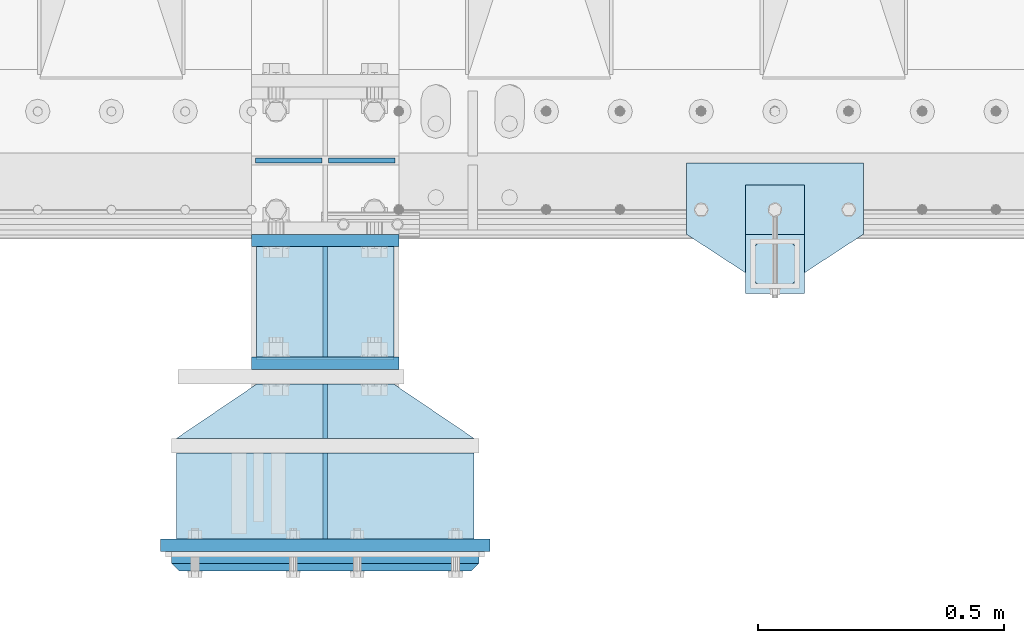
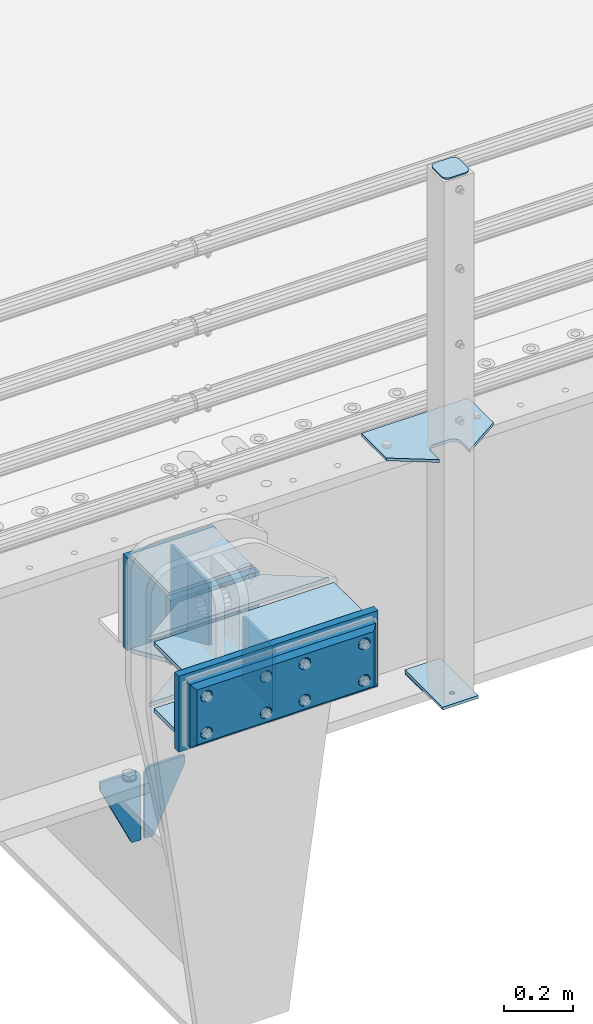
# One storey, part 223 of 270: 19 plates.
"""IFC2X3 building model written with IfcOpenShell, lengths in millimetres."""

from ifc_helpers import new_model, si_unit, frame, origin_with_axes, place, context, subcontext, project, spatial, faceted_brep, material, type_object, element, save


model = new_model("IFC2X3")

# Units and contexts
model_context = context("Model", 3, precision=1e-05, world=origin_with_axes())
body_context = subcontext(model_context, "Body", "Model", "MODEL_VIEW")
ifc_project = project(units=[si_unit("LENGTHUNIT", "METRE", prefix="MILLI"), si_unit("AREAUNIT", "SQUARE_METRE"), si_unit("VOLUMEUNIT", "CUBIC_METRE"), si_unit("MASSUNIT", "GRAM", prefix="KILO"), si_unit("TIMEUNIT", "SECOND"), si_unit("PLANEANGLEUNIT", "RADIAN"), si_unit("SOLIDANGLEUNIT", "STERADIAN"), si_unit("THERMODYNAMICTEMPERATUREUNIT", "DEGREE_CELSIUS"), si_unit("LUMINOUSINTENSITYUNIT", "LUMEN")], contexts=[model_context])

# Site, building, storey
site_placement = place(None, origin_with_axes())
site = spatial("IfcSite", under=ifc_project, at=site_placement, CompositionType="ELEMENT")
building_placement = place(site_placement, origin_with_axes())
building = spatial("IfcBuilding", under=site, at=building_placement, Name="Standard", CompositionType="ELEMENT")
storey_placement = place(building_placement, origin_with_axes())
storey = spatial("IfcBuildingStorey", under=building, at=storey_placement, Name="Undefined", CompositionType="ELEMENT", Elevation=0.0)

# Plates
ifc_material_1 = material(Name="STEEL/S355N")
plate_type_1 = type_object("IfcPlateType", PredefinedType="NOTDEFINED")
plate_1_placement = place(storey_placement, frame((13885.0000000054, -24162.5000000457, -350.00001823894), z_axis=(0.0, 0.0, 1.0), x_axis=(1.0, 0.0, 0.0)))
element("IfcPlate", 1, at=plate_1_placement, inside=storey, type_object=plate_type_1, material=ifc_material_1, context=body_context, shape_type="Brep", body=[
    faceted_brep([(0.0, -12.5, 0.0), (0.0, -12.5, 330.0), (0.0, 12.5, 330.0), (0.0, 12.5, 0.0), (300.0, -12.5, 330.0), (300.0, 12.5, 330.0), (300.0, -12.5, 0.0), (300.0, 12.5, 0.0)], [[[0, 1, 2, 3]], [[1, 4, 5, 2]], [[4, 6, 7, 5]], [[6, 0, 3, 7]], [[5, 7, 3, 2]], [[6, 4, 1, 0]]]),
])
plate_type_2 = type_object("IfcPlateType", PredefinedType="NOTDEFINED")
plate_2_placement = place(storey_placement, frame((14035.0000000058, -24175.0000000457, -346.00001823894), z_axis=(0.0, -1.0, 0.0), x_axis=(0.0, 0.0, 1.0)))
element("IfcPlate", 2, at=plate_2_placement, inside=storey, type_object=plate_type_2, material=ifc_material_1, context=body_context, shape_type="Brep", body=[
    faceted_brep([(0.0, -5.0, 0.0), (100.0, -5.0, 225.0), (100.0, 5.0, 225.0), (0.0, 5.0, 0.0), (322.0, -5.0, 225.0), (322.0, 5.0, 225.0), (322.0, -5.0, 0.0), (322.0, 5.0, 0.0)], [[[0, 1, 2, 3]], [[1, 4, 5, 2]], [[4, 6, 7, 5]], [[6, 0, 3, 7]], [[5, 7, 3, 2]], [[6, 4, 1, 0]]]),
])
ifc_material_2 = material(Name="STEEL/S355J2")
plate_type_3 = type_object("IfcPlateType", PredefinedType="NOTDEFINED")
plate_3_placement = place(storey_placement, frame((15130.0, -24005.0, 5.00000000004911), z_axis=(0.0, -1.0, 0.0), x_axis=(-1.0, 0.0, 0.0)))
element("IfcPlate", 3, at=plate_3_placement, inside=storey, type_object=plate_type_3, material=ifc_material_2, context=body_context, shape_type="Brep", body=[
    faceted_brep([(0.0, -5.0, 0.0), (2.31396552408114e-06, -5.0, 145.0), (2.31396552408114e-06, 5.0, 145.0), (0.0, 5.0, 0.0), (130.0, -5.0, 230.0), (130.0, 5.0, 230.0), (130.0, -5.0, 180.0), (130.0, 5.0, 180.0), (130.48036798992, -5.0, 175.122741949597), (130.48036798992, 5.0, 175.122741949597), (131.903011687216, -5.0, 170.432914190873), (131.903011687216, 5.0, 170.432914190873), (134.213259692435, -5.0, 166.11074417451), (134.213259692435, 5.0, 166.11074417451), (137.322330470335, -5.0, 162.322330470337), (137.322330470335, 5.0, 162.322330470337), (141.110744174512, -5.0, 159.213259692437), (141.110744174512, 5.0, 159.213259692437), (145.432914190871, -5.0, 156.903011687218), (145.432914190871, 5.0, 156.903011687218), (150.122741949595, -5.0, 155.48036798992), (150.122741949595, 5.0, 155.48036798992), (155.0, -5.0, 155.0), (155.0, 5.0, 155.0), (205.0, -5.0, 155.0), (205.0, 5.0, 155.0), (209.877258050405, -5.0, 155.48036798992), (209.877258050405, 5.0, 155.48036798992), (214.567085809129, -5.0, 156.903011687218), (214.567085809129, 5.0, 156.903011687218), (218.889255825488, -5.0, 159.213259692437), (218.889255825488, 5.0, 159.213259692437), (222.677669529665, -5.0, 162.322330470337), (222.677669529665, 5.0, 162.322330470337), (225.786740307565, -5.0, 166.11074417451), (225.786740307565, 5.0, 166.11074417451), (228.096988312784, -5.0, 170.432914190873), (228.096988312784, 5.0, 170.432914190873), (229.51963201008, -5.0, 175.122741949597), (229.51963201008, 5.0, 175.122741949597), (230.0, -5.0, 180.0), (230.0, 5.0, 180.0), (230.0, -5.0, 230.0), (230.0, 5.0, 230.0), (360.0, -5.0, 145.0), (360.0, 5.0, 145.0), (360.0, -5.0, -7.27595761418343e-12), (360.0, 5.0, -7.27595761418343e-12)], [[[0, 1, 2, 3]], [[1, 4, 5, 2]], [[4, 6, 7, 5]], [[6, 8, 9, 7]], [[8, 10, 11, 9]], [[10, 12, 13, 11]], [[12, 14, 15, 13]], [[14, 16, 17, 15]], [[16, 18, 19, 17]], [[18, 20, 21, 19]], [[20, 22, 23, 21]], [[22, 24, 25, 23]], [[24, 26, 27, 25]], [[26, 28, 29, 27]], [[28, 30, 31, 29]], [[30, 32, 33, 31]], [[32, 34, 35, 33]], [[34, 36, 37, 35]], [[36, 38, 39, 37]], [[38, 40, 41, 39]], [[40, 42, 43, 41]], [[42, 44, 45, 43]], [[44, 46, 47, 45]], [[46, 0, 3, 47]], [[5, 7, 9, 11, 13, 15, 17, 19, 21, 23, 25, 27, 29, 31, 33, 35, 37, 39, 41, 43, 45, 47, 3, 2]], [[46, 44, 42, 40, 38, 36, 34, 32, 30, 28, 26, 24, 22, 20, 18, 16, 14, 12, 10, 8, 6, 4, 1, 0]]]),
])
plate_type_4 = type_object("IfcPlateType", PredefinedType="NOTDEFINED")
plate_4_placement = place(storey_placement, frame((15009.9999999999, -24050.0000000002, -850.000000000002), z_axis=(0.0, -1.0, 0.0), x_axis=(-1.0, 0.0, 0.0)))
element("IfcPlate", 4, at=plate_4_placement, inside=storey, type_object=plate_type_4, material=ifc_material_2, context=body_context, shape_type="Brep", body=[
    faceted_brep([(53.6360389691836, -5.0, 176.363961030471), (53.6360389691836, 5.0, 176.363961030471), (59.9999999998618, 5.0, 178.999999999793), (59.9999999998618, -5.0, 178.999999999793), (66.3639610305399, 5.0, 176.363961030471), (66.3639610305399, -5.0, 176.363961030471), (68.9999999998618, 5.0, 169.999999999793), (68.9999999998618, -5.0, 169.999999999793), (66.3639610305399, 5.0, 163.636038969114), (66.3639610305399, -5.0, 163.636038969114), (59.9999999998618, 5.0, 160.999999999793), (59.9999999998618, -5.0, 160.999999999793), (53.6360389691836, 5.0, 163.636038969114), (53.6360389691836, -5.0, 163.636038969114), (50.9999999998618, 5.0, 169.999999999793), (50.9999999998618, -5.0, 169.999999999793), (120.0, -5.0, 0.0), (120.0, -5.0, 220.0), (0.0, -5.0, 220.0), (0.0, -5.0, 0.0), (0.0, 5.0, 0.0), (120.0, 5.0, 0.0), (120.0, 5.0, 220.0), (0.0, 5.0, 220.0)], [[[0, 1, 2, 3]], [[3, 2, 4, 5]], [[5, 4, 6, 7]], [[7, 6, 8, 9]], [[9, 8, 10, 11]], [[11, 10, 12, 13]], [[13, 12, 14, 15]], [[15, 14, 1, 0]], [[16, 17, 18, 19], [11, 13, 15, 0, 3, 5, 7, 9]], [[16, 19, 20, 21]], [[17, 16, 21, 22]], [[18, 17, 22, 23]], [[19, 18, 23, 20]], [[22, 21, 20, 23], [2, 1, 14, 12, 10, 8, 6, 4]]]),
])
plate_type_5 = type_object("IfcPlateType", PredefinedType="NOTDEFINED")
plate_5_placement = place(storey_placement, frame((14905.9999999999, -24166.0000000002, 1012.50000000001), z_axis=(0.0, -1.0, 0.0), x_axis=(1.0, 0.0, 0.0)))
element("IfcPlate", 5, at=plate_5_placement, inside=storey, type_object=plate_type_5, material=ifc_material_2, context=body_context, shape_type="Brep", body=[
    faceted_brep([(0.0, -2.5, 19.0), (0.0, -2.5, 69.0), (0.0, 2.5, 69.0), (0.0, 2.5, 19.0), (0.476369668544066, -2.5, 73.2278977451697), (0.476369668544066, 2.5, 73.2278977451697), (1.88159150985302, -2.5, 77.2437910432327), (1.88159150985302, 2.5, 77.2437910432327), (4.14520183310742, -2.5, 80.8463062353167), (4.14520183310742, 2.5, 80.8463062353167), (7.15369376468516, -2.5, 83.8547981668926), (7.15369376468516, 2.5, 83.8547981668926), (10.7562089567655, -2.5, 86.1184084901452), (10.7562089567655, 2.5, 86.1184084901452), (14.7721022548285, -2.5, 87.5236303314541), (14.7721022548285, 2.5, 87.5236303314541), (19.0, -2.5, 88.0), (19.0, 2.5, 88.0), (69.0, -2.5, 88.0), (69.0, 2.5, 88.0), (73.2278977451715, -2.5, 87.5236303314541), (73.2278977451715, 2.5, 87.5236303314541), (77.2437910432345, -2.5, 86.1184084901452), (77.2437910432345, 2.5, 86.1184084901452), (80.8463062353148, -2.5, 83.8547981668926), (80.8463062353148, 2.5, 83.8547981668926), (83.8547981668926, -2.5, 80.8463062353167), (83.8547981668926, 2.5, 80.8463062353167), (86.118408490147, -2.5, 77.2437910432345), (86.118408490147, 2.5, 77.2437910432345), (87.5236303314559, -2.5, 73.2278977451697), (87.5236303314559, 2.5, 73.2278977451697), (88.0, -2.5, 69.0), (88.0, 2.5, 69.0), (88.0, -2.5, 19.0), (88.0, 2.5, 19.0), (87.5236303314559, -2.5, 14.7721022548303), (87.5236303314559, 2.5, 14.7721022548303), (86.118408490147, -2.5, 10.7562089567673), (86.118408490147, 2.5, 10.7562089567673), (83.8547981668926, -2.5, 7.15369376468334), (83.8547981668926, 2.5, 7.15369376468334), (80.8463062353148, -2.5, 4.14520183310742), (80.8463062353148, 2.5, 4.14520183310742), (77.2437910432345, -2.5, 1.88159150985484), (77.2437910432345, 2.5, 1.88159150985484), (73.2278977451715, -2.5, 0.476369668545885), (73.2278977451715, 2.5, 0.476369668545885), (69.0, -2.5, 0.0), (69.0, 2.5, 0.0), (19.0, -2.5, 0.0), (19.0, 2.5, 0.0), (14.7721022548285, -2.5, 0.476369668545885), (14.7721022548285, 2.5, 0.476369668545885), (10.7562089567655, -2.5, 1.88159150985484), (10.7562089567655, 2.5, 1.88159150985484), (7.15369376468516, -2.5, 4.14520183310742), (7.15369376468516, 2.5, 4.14520183310742), (4.14520183310742, -2.5, 7.15369376468334), (4.14520183310742, 2.5, 7.15369376468334), (1.88159150985302, -2.5, 10.7562089567673), (1.88159150985302, 2.5, 10.7562089567673), (0.476369668544066, -2.5, 14.7721022548303), (0.476369668544066, 2.5, 14.7721022548303)], [[[0, 1, 2, 3]], [[1, 4, 5, 2]], [[4, 6, 7, 5]], [[6, 8, 9, 7]], [[8, 10, 11, 9]], [[10, 12, 13, 11]], [[12, 14, 15, 13]], [[14, 16, 17, 15]], [[16, 18, 19, 17]], [[18, 20, 21, 19]], [[20, 22, 23, 21]], [[22, 24, 25, 23]], [[24, 26, 27, 25]], [[26, 28, 29, 27]], [[28, 30, 31, 29]], [[30, 32, 33, 31]], [[32, 34, 35, 33]], [[34, 36, 37, 35]], [[36, 38, 39, 37]], [[38, 40, 41, 39]], [[40, 42, 43, 41]], [[42, 44, 45, 43]], [[44, 46, 47, 45]], [[46, 48, 49, 47]], [[48, 50, 51, 49]], [[50, 52, 53, 51]], [[52, 54, 55, 53]], [[54, 56, 57, 55]], [[56, 58, 59, 57]], [[58, 60, 61, 59]], [[60, 62, 63, 61]], [[62, 0, 3, 63]], [[5, 7, 9, 11, 13, 15, 17, 19, 21, 23, 25, 27, 29, 31, 33, 35, 37, 39, 41, 43, 45, 47, 49, 51, 53, 55, 57, 59, 61, 63, 3, 2]], [[62, 60, 58, 56, 54, 52, 50, 48, 46, 44, 42, 40, 38, 36, 34, 32, 30, 28, 26, 24, 22, 20, 18, 16, 14, 12, 10, 8, 6, 4, 1, 0]]]),
])
plate_type_6 = type_object("IfcPlateType", PredefinedType="NOTDEFINED")
plate_6_placement = place(storey_placement, frame((15009.9999999999, -24050.0000000002, -857.500000000002), z_axis=(0.0, -1.0, 0.0), x_axis=(-1.0, 0.0, 0.0)))
element("IfcPlate", 6, at=plate_6_placement, inside=storey, type_object=plate_type_6, material=ifc_material_2, context=body_context, shape_type="Brep", body=[
    faceted_brep([(0.0, -2.5, 0.0), (0.0, -2.5, 100.0), (0.0, 2.5, 100.0), (0.0, 2.5, 0.0), (120.0, -2.5, 100.0), (120.0, 2.5, 100.0), (120.0, -2.5, 0.0), (120.0, 2.5, 0.0)], [[[0, 1, 2, 3]], [[1, 4, 5, 2]], [[4, 6, 7, 5]], [[6, 0, 3, 7]], [[5, 7, 3, 2]], [[6, 4, 1, 0]]]),
])
plate_type_7 = type_object("IfcPlateType", PredefinedType="NOTDEFINED")
for number, where, z_axis, x_axis in (
    (7, (14028.5000000058, -24000.0000000457, -925.000018238938), (0.0, 0.0, -1.0), (-1.0, 0.0, 0.0)),
    (8, (14041.5000000058, -24000.0000000457, -925.000018238938), (0.0, 0.0, -1.0), (1.0, 0.0, 0.0)),
):
    element("IfcPlate", number, at=place(storey_placement, frame(where, z_axis=z_axis, x_axis=x_axis)), inside=storey, type_object=plate_type_7, material=ifc_material_1, context=body_context, shape_type="Brep", body=[
        faceted_brep([(0.0, -5.0, 27.0), (0.0, -5.0, 250.0), (0.0, 5.0, 250.0), (0.0, 5.0, 27.0), (30.0, -5.0, 250.0), (30.0, 5.0, 250.0), (135.0, -5.0, 30.0), (135.0, 5.0, 30.0), (135.0, -5.0, 0.0), (135.0, 5.0, 0.0), (27.0, -5.0, 0.0), (27.0, 5.0, 0.0), (22.3114992029932, -5.0, 0.410190668670339), (22.3114992029932, 5.0, 0.410190668670339), (17.7654561302061, -5.0, 1.62829923878053), (17.7654561302061, 5.0, 1.62829923878053), (13.5, -5.0, 3.6173140978201), (13.5, 5.0, 3.6173140978201), (9.64473453846404, -5.0, 6.31680003578754), (9.64473453846404, 5.0, 6.31680003578754), (6.31680003578731, -5.0, 9.64473453846347), (6.31680003578731, 5.0, 9.64473453846347), (3.61731409782078, -5.0, 13.5), (3.61731409782078, 5.0, 13.5), (1.62829923878053, -5.0, 17.765456130207), (1.62829923878053, 5.0, 17.765456130207), (0.410190668670111, -5.0, 22.3114992029929), (0.410190668670111, 5.0, 22.3114992029929)], [[[0, 1, 2, 3]], [[1, 4, 5, 2]], [[4, 6, 7, 5]], [[6, 8, 9, 7]], [[8, 10, 11, 9]], [[10, 12, 13, 11]], [[12, 14, 15, 13]], [[14, 16, 17, 15]], [[16, 18, 19, 17]], [[18, 20, 21, 19]], [[20, 22, 23, 21]], [[22, 24, 25, 23]], [[24, 26, 27, 25]], [[26, 0, 3, 27]], [[5, 7, 9, 11, 13, 15, 17, 19, 21, 23, 25, 27, 3, 2]], [[26, 24, 22, 20, 18, 16, 14, 12, 10, 8, 6, 4, 1, 0]]]),
    ])
plate_type_8 = type_object("IfcPlateType", PredefinedType="NOTDEFINED")
plate_7_placement = place(storey_placement, frame((14035.000000006, -24770.0000000457, -24.0000182389397), z_axis=(0.0, 0.0, -1.0), x_axis=(0.0, 1.0, 0.0)))
element("IfcPlate", 9, at=plate_7_placement, inside=storey, type_object=plate_type_8, material=ifc_material_1, context=body_context, shape_type="Brep", body=[
    faceted_brep([(0.0, -5.0, 0.0), (0.0, -5.0, 222.0), (0.0, 5.0, 222.0), (0.0, 5.0, 0.0), (175.0, -5.0, 222.0), (175.0, 5.0, 222.0), (175.0, -5.0, 0.0), (175.0, 5.0, 0.0)], [[[0, 1, 2, 3]], [[1, 4, 5, 2]], [[4, 6, 7, 5]], [[6, 0, 3, 7]], [[5, 7, 3, 2]], [[6, 4, 1, 0]]]),
])
plate_type_9 = type_object("IfcPlateType", PredefinedType="NOTDEFINED")
plate_8_placement = place(storey_placement, frame((14035.0000000059, -24565.0000000457, -24.0000182389397), z_axis=(0.0, 0.0, -1.0), x_axis=(0.0, 1.0, 0.0)))
element("IfcPlate", 10, at=plate_8_placement, inside=storey, type_object=plate_type_9, material=ifc_material_1, context=body_context, shape_type="Brep", body=[
    faceted_brep([(0.0, -5.0, 0.0), (0.0, -5.0, 222.0), (0.0, 5.0, 222.0), (0.0, 5.0, 0.0), (110.0, -5.0, 222.0), (110.0, 5.0, 222.0), (110.0, -5.0, 0.0), (110.0, 5.0, 0.0)], [[[0, 1, 2, 3]], [[1, 4, 5, 2]], [[4, 6, 7, 5]], [[6, 0, 3, 7]], [[5, 7, 3, 2]], [[6, 4, 1, 0]]]),
])
ifc_material_3 = material()
plate_type_10 = type_object("IfcPlateType", PredefinedType="NOTDEFINED")
for number, where, z_axis, x_axis in (
    (11, (14337.5000000068, -24595.0000000458, -17.0000182389397), (0.0, -1.0, 0.0), (-1.0, 0.0, 0.0)),
    (12, (14337.5000000068, -24595.0000000458, -253.00001823894), (0.0, -1.0, 0.0), (-1.0, 0.0, 0.0)),
):
    element("IfcPlate", number, at=place(storey_placement, frame(where, z_axis=z_axis, x_axis=x_axis)), inside=storey, type_object=plate_type_10, material=ifc_material_3, context=body_context, shape_type="Brep", body=[
        faceted_brep([(0.0, -7.0, 0.0), (0.0, -7.0, 175.0), (0.0, 7.0, 175.0), (0.0, 7.0, 0.0), (605.0, -7.0, 175.0), (605.0, 7.0, 175.0), (605.0, -7.0, 0.0), (605.0, 7.0, 0.0)], [[[0, 1, 2, 3]], [[1, 4, 5, 2]], [[4, 6, 7, 5]], [[6, 0, 3, 7]], [[5, 7, 3, 2]], [[6, 4, 1, 0]]]),
    ])
plate_type_11 = type_object("IfcPlateType", PredefinedType="NOTDEFINED")
for number, where, z_axis, x_axis in (
    (13, (14337.5000000068, -24565.0000000458, -253.00001823894), (-0.560566412034006, -0.828109472050236, 0.0), (-0.828109472050238, 0.560566412034004, 0.0)),
    (14, (14337.5000000068, -24565.0000000458, -17.0000182389397), (-0.560566412034006, -0.828109472050236, 0.0), (-0.828109472050238, 0.560566412034004, 0.0)),
):
    element("IfcPlate", number, at=place(storey_placement, frame(where, z_axis=z_axis, x_axis=x_axis)), inside=storey, type_object=plate_type_11, material=ifc_material_1, context=body_context, shape_type="Brep", body=[
        faceted_brep([(0.0, -7.0, 0.0), (501.006225585938, -7.0, 339.142669677731), (501.006225585938, 7.0, 339.142669677731), (0.0, 7.0, 0.0), (428.100738525392, -7.0, 156.95860290527), (428.100738525392, 7.0, 156.95860290527), (196.230087280276, -7.0, -4.00177668780088e-11), (196.230087280276, 7.0, -4.00177668780088e-11)], [[[0, 1, 2, 3]], [[1, 4, 5, 2]], [[4, 6, 7, 5]], [[6, 0, 3, 7]], [[5, 7, 3, 2]], [[6, 4, 1, 0]]]),
    ])
plate_type_12 = type_object("IfcPlateType", PredefinedType="NOTDEFINED")
plate_9_placement = place(storey_placement, frame((14370.0000000069, -24782.5000000458, -1.823893967412e-05), z_axis=(0.0, 0.0, -1.0), x_axis=(-1.0, 0.0, 0.0)))
element("IfcPlate", 15, at=plate_9_placement, inside=storey, type_object=plate_type_12, material=ifc_material_1, context=body_context, shape_type="Brep", body=[
    faceted_brep([(0.0, -12.5, 0.0), (0.0, -12.5, 270.0), (0.0, 12.5, 270.0), (0.0, 12.5, 0.0), (670.0, -12.5, 270.0), (670.0, 12.5, 270.0), (670.0, -12.5, 0.0), (670.0, 12.5, 0.0)], [[[0, 1, 2, 3]], [[1, 4, 5, 2]], [[4, 6, 7, 5]], [[6, 0, 3, 7]], [[5, 7, 3, 2]], [[6, 4, 1, 0]]]),
])
plate_type_13 = type_object("IfcPlateType", PredefinedType="NOTDEFINED")
plate_10_placement = place(storey_placement, frame((13885.0000000055, -24412.5000000457, -250.00001823894), z_axis=(0.0, 0.0, 1.0), x_axis=(1.0, 0.0, 0.0)))
element("IfcPlate", 16, at=plate_10_placement, inside=storey, type_object=plate_type_13, material=ifc_material_1, context=body_context, shape_type="Brep", body=[
    faceted_brep([(0.0, -12.5, 0.0), (0.0, -12.5, 230.0), (0.0, 12.5, 230.0), (0.0, 12.5, 0.0), (300.0, -12.5, 230.0), (300.0, 12.5, 230.0), (300.0, -12.5, 0.0), (300.0, 12.5, 0.0)], [[[0, 1, 2, 3]], [[1, 4, 5, 2]], [[4, 6, 7, 5]], [[6, 0, 3, 7]], [[5, 7, 3, 2]], [[6, 4, 1, 0]]]),
])
ifc_material_4 = material()
plate_type_14 = type_object("IfcPlateType", PredefinedType="NOTDEFINED")
plate_11_placement = place(storey_placement, frame((14347.5000000069, -24815.0000000458, -22.5000182389397), z_axis=(0.0, 0.0, -1.0), x_axis=(-1.0, 0.0, 0.0)))
element("IfcPlate", 17, at=plate_11_placement, inside=storey, type_object=plate_type_14, material=ifc_material_4, context=body_context, shape_type="Brep", body=[
    faceted_brep([(0.0, -5.0, 0.0), (15.0, -20.0, 15.0), (15.0, -20.0, 210.0), (0.0, -5.0, 225.0), (625.0, -5.0, 225.0), (610.0, -20.0, 210.0), (610.0, -20.0, 15.0), (625.0, -5.0, 0.0), (625.0, 15.0, 0.0), (620.0, 20.0, 5.0), (620.0, 20.0, 220.0), (625.0, 15.0, 225.0), (0.0, 15.0, 225.0), (5.0, 20.0, 220.0), (5.0, 20.0, 5.0), (0.0, 15.0, 0.0), (30.1794919244185, 5.00000000001455, 37.4999999999982), (37.5000000001073, 5.00000000001455, 30.1794919243094), (47.5000000001073, 5.00000000001455, 27.4999999999982), (57.5000000001073, 5.00000000001455, 30.1794919243094), (64.8205080757962, 5.00000000001455, 37.4999999999982), (67.5000000001073, 5.00000000001455, 47.4999999999982), (64.8205080757962, 5.00000000001455, 57.4999999999982), (57.5000000001073, 5.00000000001455, 64.8205080756869), (47.5000000001073, 5.00000000001455, 67.4999999999982), (37.5000000001073, 5.00000000001455, 64.820508075687), (30.1794919244185, 5.00000000001455, 57.4999999999982), (27.5000000001073, 5.00000000001455, 47.4999999999982), (37.5000000001073, -20.0, 30.1794919243094), (30.1794919244185, -20.0, 37.4999999999982), (47.5000000001073, -20.0, 27.4999999999982), (57.5000000001073, -20.0, 30.1794919243094), (64.8205080757962, -20.0, 37.4999999999982), (67.5000000001073, -20.0, 47.4999999999982), (64.8205080757962, -20.0, 57.4999999999982), (57.5000000001073, -20.0, 64.8205080756869), (47.5000000001073, -20.0, 67.4999999999982), (37.5000000001073, -20.0, 64.820508075687), (30.1794919244185, -20.0, 57.4999999999982), (27.5000000001073, -20.0, 47.4999999999982), (360.179491925306, 5.00000000012005, 37.4999999999982), (367.500000000995, 5.00000000012005, 30.1794919243094), (377.500000000995, 5.00000000012005, 27.4999999999982), (387.500000000995, 5.00000000012005, 30.1794919243094), (394.820508076684, 5.00000000012005, 37.4999999999982), (397.500000000995, 5.00000000012005, 47.4999999999982), (394.820508076684, 5.00000000012005, 57.4999999999982), (387.500000000995, 5.00000000012005, 64.8205080756869), (377.500000000995, 5.00000000012005, 67.4999999999982), (367.500000000995, 5.00000000012005, 64.820508075687), (360.179491925306, 5.00000000012005, 57.4999999999982), (357.500000000995, 5.00000000012005, 47.4999999999982), (360.179491925306, -20.0, 37.4999999999982), (357.500000000995, -20.0, 47.4999999999982), (367.500000000995, -20.0, 30.1794919243094), (377.500000000995, -20.0, 27.4999999999982), (387.500000000995, -20.0, 30.1794919243094), (394.820508076684, -20.0, 37.4999999999982), (397.500000000995, -20.0, 47.4999999999982), (394.820508076684, -20.0, 57.4999999999982), (387.500000000995, -20.0, 64.8205080756869), (377.500000000995, -20.0, 67.4999999999982), (367.500000000995, -20.0, 64.820508075687), (360.179491925306, -20.0, 57.4999999999982), (360.179491925306, 5.00000000012005, 167.499999999998), (367.500000000995, 5.00000000012005, 160.179491924309), (377.500000000995, 5.00000000012005, 157.499999999998), (387.500000000995, 5.00000000012005, 160.179491924309), (394.820508076684, 5.00000000012005, 167.499999999998), (397.500000000995, 5.00000000012005, 177.499999999998), (394.820508076684, 5.00000000012005, 187.499999999998), (387.500000000995, 5.00000000012005, 194.820508075687), (377.500000000995, 5.00000000012005, 197.499999999998), (367.500000000995, 5.00000000012005, 194.820508075687), (360.179491925306, 5.00000000012005, 187.499999999998), (357.500000000995, 5.00000000012005, 177.499999999998), (360.179491925306, -20.0, 167.499999999998), (357.500000000995, -20.0, 177.499999999998), (367.500000000995, -20.0, 160.179491924309), (377.500000000995, -20.0, 157.499999999998), (387.500000000995, -20.0, 160.179491924309), (394.820508076684, -20.0, 167.499999999998), (397.500000000995, -20.0, 177.499999999998), (394.820508076684, -20.0, 187.499999999998), (387.500000000995, -20.0, 194.820508075687), (377.500000000995, -20.0, 197.499999999998), (367.500000000995, -20.0, 194.820508075687), (360.179491925306, -20.0, 187.499999999998), (560.179491925845, 5.0000000001819, 167.499999999998), (567.500000001533, 5.0000000001819, 160.179491924309), (577.500000001533, 5.0000000001819, 157.499999999998), (587.500000001533, 5.0000000001819, 160.179491924309), (594.820508077222, 5.0000000001819, 167.499999999998), (597.500000001533, 5.0000000001819, 177.499999999998), (594.820508077222, 5.0000000001819, 187.499999999998), (587.500000001533, 5.0000000001819, 194.820508075687), (577.500000001533, 5.0000000001819, 197.499999999998), (567.500000001533, 5.0000000001819, 194.820508075687), (560.179491925845, 5.0000000001819, 187.499999999998), (557.500000001533, 5.0000000001819, 177.499999999998), (560.179491925845, -20.0, 167.499999999998), (557.500000001533, -20.0, 177.499999999998), (567.500000001533, -20.0, 160.179491924309), (577.500000001533, -20.0, 157.499999999998), (587.500000001533, -20.0, 160.179491924309), (594.820508077222, -20.0, 167.499999999998), (597.500000001533, -20.0, 177.499999999998), (594.820508077222, -20.0, 187.499999999998), (587.500000001533, -20.0, 194.820508075687), (577.500000001533, -20.0, 197.499999999998), (567.500000001533, -20.0, 194.820508075687), (560.179491925845, -20.0, 187.499999999998), (230.179491924957, 5.0000000000764, 37.4999999999982), (237.500000000646, 5.0000000000764, 30.1794919243094), (247.500000000646, 5.0000000000764, 27.4999999999982), (257.500000000646, 5.0000000000764, 30.1794919243094), (264.820508076335, 5.0000000000764, 37.4999999999982), (267.500000000646, 5.0000000000764, 47.4999999999982), (264.820508076335, 5.0000000000764, 57.4999999999982), (257.500000000646, 5.0000000000764, 64.8205080756869), (247.500000000646, 5.0000000000764, 67.4999999999982), (237.500000000646, 5.0000000000764, 64.820508075687), (230.179491924957, 5.0000000000764, 57.4999999999982), (227.500000000646, 5.0000000000764, 47.4999999999982), (230.179491924957, -20.0, 37.4999999999982), (227.500000000646, -20.0, 47.4999999999982), (237.500000000646, -20.0, 30.1794919243094), (247.500000000646, -20.0, 27.4999999999982), (257.500000000646, -20.0, 30.1794919243094), (264.820508076335, -20.0, 37.4999999999982), (267.500000000646, -20.0, 47.4999999999982), (264.820508076335, -20.0, 57.4999999999982), (257.500000000646, -20.0, 64.8205080756869), (247.500000000646, -20.0, 67.4999999999982), (237.500000000646, -20.0, 64.820508075687), (230.179491924957, -20.0, 57.4999999999982), (30.1794919244185, 5.00000000001455, 167.499999999998), (37.5000000001073, 5.00000000001455, 160.179491924309), (47.5000000001073, 5.00000000001455, 157.499999999998), (57.5000000001073, 5.00000000001455, 160.179491924309), (64.8205080757962, 5.00000000001455, 167.499999999998), (67.5000000001073, 5.00000000001455, 177.499999999998), (64.8205080757962, 5.00000000001455, 187.499999999998), (57.5000000001073, 5.00000000001455, 194.820508075687), (47.5000000001073, 5.00000000001455, 197.499999999998), (37.5000000001073, 5.00000000001455, 194.820508075687), (30.1794919244185, 5.00000000001455, 187.499999999998), (27.5000000001073, 5.00000000001455, 177.499999999998), (30.1794919244185, -20.0, 167.499999999998), (27.5000000001073, -20.0, 177.499999999998), (37.5000000001073, -20.0, 160.179491924309), (47.5000000001073, -20.0, 157.499999999998), (57.5000000001073, -20.0, 160.179491924309), (64.8205080757962, -20.0, 167.499999999998), (67.5000000001073, -20.0, 177.499999999998), (64.8205080757962, -20.0, 187.499999999998), (57.5000000001073, -20.0, 194.820508075687), (47.5000000001073, -20.0, 197.499999999998), (37.5000000001073, -20.0, 194.820508075687), (30.1794919244185, -20.0, 187.499999999998), (230.179491924957, 5.0000000000764, 167.499999999998), (237.500000000646, 5.0000000000764, 160.179491924309), (247.500000000646, 5.0000000000764, 157.499999999998), (257.500000000646, 5.0000000000764, 160.179491924309), (264.820508076335, 5.0000000000764, 167.499999999998), (267.500000000646, 5.0000000000764, 177.499999999998), (264.820508076335, 5.0000000000764, 187.499999999998), (257.500000000646, 5.0000000000764, 194.820508075687), (247.500000000646, 5.0000000000764, 197.499999999998), (237.500000000646, 5.0000000000764, 194.820508075687), (230.179491924957, 5.0000000000764, 187.499999999998), (227.500000000646, 5.0000000000764, 177.499999999998), (230.179491924957, -20.0, 167.499999999998), (227.500000000646, -20.0, 177.499999999998), (237.500000000646, -20.0, 160.179491924309), (247.500000000646, -20.0, 157.499999999998), (257.500000000646, -20.0, 160.179491924309), (264.820508076335, -20.0, 167.499999999998), (267.500000000646, -20.0, 177.499999999998), (264.820508076335, -20.0, 187.499999999998), (257.500000000646, -20.0, 194.820508075687), (247.500000000646, -20.0, 197.499999999998), (237.500000000646, -20.0, 194.820508075687), (230.179491924957, -20.0, 187.499999999998), (560.179491925845, 5.0000000001819, 37.4999999999982), (567.500000001533, 5.0000000001819, 30.1794919243094), (577.500000001533, 5.0000000001819, 27.4999999999982), (587.500000001533, 5.0000000001819, 30.1794919243094), (594.820508077222, 5.0000000001819, 37.4999999999982), (597.500000001533, 5.0000000001819, 47.4999999999982), (594.820508077222, 5.0000000001819, 57.4999999999982), (587.500000001533, 5.0000000001819, 64.8205080756869), (577.500000001533, 5.0000000001819, 67.4999999999982), (567.500000001533, 5.0000000001819, 64.820508075687), (560.179491925845, 5.0000000001819, 57.4999999999982), (557.500000001533, 5.0000000001819, 47.4999999999982), (560.179491925845, -20.0, 37.4999999999982), (557.500000001533, -20.0, 47.4999999999982), (567.500000001533, -20.0, 30.1794919243094), (577.500000001533, -20.0, 27.4999999999982), (587.500000001533, -20.0, 30.1794919243094), (594.820508077222, -20.0, 37.4999999999982), (597.500000001533, -20.0, 47.4999999999982), (594.820508077222, -20.0, 57.4999999999982), (587.500000001533, -20.0, 64.8205080756869), (577.500000001533, -20.0, 67.4999999999982), (567.500000001533, -20.0, 64.820508075687), (560.179491925845, -20.0, 57.4999999999982)], [[[0, 1, 2, 3]], [[4, 5, 6, 7]], [[8, 9, 10, 11]], [[12, 13, 14, 15]], [[15, 14, 9, 8]], [[5, 4, 3, 2]], [[13, 12, 11, 10]], [[7, 6, 1, 0]], [[16, 17, 18, 19, 20, 21, 22, 23, 24, 25, 26, 27]], [[28, 17, 16, 29]], [[30, 18, 17, 28]], [[31, 19, 18, 30]], [[32, 20, 19, 31]], [[33, 21, 20, 32]], [[34, 22, 21, 33]], [[35, 23, 22, 34]], [[36, 24, 23, 35]], [[37, 25, 24, 36]], [[38, 26, 25, 37]], [[39, 27, 26, 38]], [[29, 16, 27, 39]], [[11, 12, 3, 4]], [[8, 11, 4, 7]], [[7, 0, 15, 8]], [[14, 13, 10, 9]], [[12, 15, 0, 3]], [[40, 41, 42, 43, 44, 45, 46, 47, 48, 49, 50, 51]], [[52, 40, 51, 53]], [[54, 41, 40, 52]], [[55, 42, 41, 54]], [[56, 43, 42, 55]], [[57, 44, 43, 56]], [[58, 45, 44, 57]], [[59, 46, 45, 58]], [[60, 47, 46, 59]], [[61, 48, 47, 60]], [[62, 49, 48, 61]], [[63, 50, 49, 62]], [[53, 51, 50, 63]], [[64, 65, 66, 67, 68, 69, 70, 71, 72, 73, 74, 75]], [[76, 64, 75, 77]], [[78, 65, 64, 76]], [[79, 66, 65, 78]], [[80, 67, 66, 79]], [[81, 68, 67, 80]], [[82, 69, 68, 81]], [[83, 70, 69, 82]], [[84, 71, 70, 83]], [[85, 72, 71, 84]], [[86, 73, 72, 85]], [[87, 74, 73, 86]], [[77, 75, 74, 87]], [[88, 89, 90, 91, 92, 93, 94, 95, 96, 97, 98, 99]], [[100, 88, 99, 101]], [[102, 89, 88, 100]], [[103, 90, 89, 102]], [[104, 91, 90, 103]], [[105, 92, 91, 104]], [[106, 93, 92, 105]], [[107, 94, 93, 106]], [[108, 95, 94, 107]], [[109, 96, 95, 108]], [[110, 97, 96, 109]], [[111, 98, 97, 110]], [[101, 99, 98, 111]], [[112, 113, 114, 115, 116, 117, 118, 119, 120, 121, 122, 123]], [[124, 112, 123, 125]], [[126, 113, 112, 124]], [[127, 114, 113, 126]], [[128, 115, 114, 127]], [[129, 116, 115, 128]], [[130, 117, 116, 129]], [[131, 118, 117, 130]], [[132, 119, 118, 131]], [[133, 120, 119, 132]], [[134, 121, 120, 133]], [[135, 122, 121, 134]], [[125, 123, 122, 135]], [[136, 137, 138, 139, 140, 141, 142, 143, 144, 145, 146, 147]], [[148, 136, 147, 149]], [[150, 137, 136, 148]], [[151, 138, 137, 150]], [[152, 139, 138, 151]], [[153, 140, 139, 152]], [[154, 141, 140, 153]], [[155, 142, 141, 154]], [[156, 143, 142, 155]], [[157, 144, 143, 156]], [[158, 145, 144, 157]], [[159, 146, 145, 158]], [[149, 147, 146, 159]], [[160, 161, 162, 163, 164, 165, 166, 167, 168, 169, 170, 171]], [[172, 160, 171, 173]], [[174, 161, 160, 172]], [[175, 162, 161, 174]], [[176, 163, 162, 175]], [[177, 164, 163, 176]], [[178, 165, 164, 177]], [[179, 166, 165, 178]], [[180, 167, 166, 179]], [[181, 168, 167, 180]], [[182, 169, 168, 181]], [[183, 170, 169, 182]], [[173, 171, 170, 183]], [[184, 185, 186, 187, 188, 189, 190, 191, 192, 193, 194, 195]], [[196, 184, 195, 197]], [[198, 185, 184, 196]], [[199, 186, 185, 198]], [[200, 187, 186, 199]], [[201, 188, 187, 200]], [[202, 189, 188, 201]], [[203, 190, 189, 202]], [[204, 191, 190, 203]], [[205, 192, 191, 204]], [[206, 193, 192, 205]], [[207, 194, 193, 206]], [[197, 195, 194, 207]], [[6, 5, 2, 1], [37, 36, 35, 34, 33, 32, 31, 30, 28, 29, 39, 38], [206, 205, 204, 203, 202, 201, 200, 199, 198, 196, 197, 207], [182, 181, 180, 179, 178, 177, 176, 175, 174, 172, 173, 183], [158, 157, 156, 155, 154, 153, 152, 151, 150, 148, 149, 159], [134, 133, 132, 131, 130, 129, 128, 127, 126, 124, 125, 135], [110, 109, 108, 107, 106, 105, 104, 103, 102, 100, 101, 111], [86, 85, 84, 83, 82, 81, 80, 79, 78, 76, 77, 87], [62, 61, 60, 59, 58, 57, 56, 55, 54, 52, 53, 63]]]),
])
plate_type_15 = type_object("IfcPlateType", PredefinedType="NOTDEFINED")
plate_12_placement = place(storey_placement, frame((13895.0000000055, -24175.0000000457, -17.0000182389397), z_axis=(0.0, -1.0, 0.0), x_axis=(1.0, 0.0, 0.0)))
element("IfcPlate", 18, at=plate_12_placement, inside=storey, type_object=plate_type_15, material=ifc_material_1, context=body_context, shape_type="Brep", body=[
    faceted_brep([(0.0, -7.0, 0.0), (0.0, -7.0, 225.0), (0.0, 7.0, 225.0), (0.0, 7.0, 0.0), (280.0, -7.0, 225.0), (280.0, 7.0, 225.0), (280.0, -7.0, 0.0), (280.0, 7.0, 0.0)], [[[0, 1, 2, 3]], [[1, 4, 5, 2]], [[4, 6, 7, 5]], [[6, 0, 3, 7]], [[5, 7, 3, 2]], [[6, 4, 1, 0]]]),
])
plate_type_16 = type_object("IfcPlateType", PredefinedType="NOTDEFINED")
plate_13_placement = place(storey_placement, frame((13895.0000000055, -24177.8429693067, -352.396699079864), z_axis=(0.0, -0.913811548702731, 0.406138465867881), x_axis=(1.0, 0.0, 0.0)))
element("IfcPlate", 19, at=plate_13_placement, inside=storey, type_object=plate_type_16, material=ifc_material_1, context=body_context, shape_type="Brep", body=[
    faceted_brep([(0.0, -7.0, 0.0), (0.0, -6.99999999999909, 246.221450805666), (0.0, 7.00000000000091, 246.221450805666), (0.0, 7.0, 0.0), (280.0, -6.99999999999909, 246.221450805666), (280.0, 7.00000000000091, 246.221450805666), (280.0, -7.0, 0.0), (280.0, 7.0, 0.0)], [[[0, 1, 2, 3]], [[1, 4, 5, 2]], [[4, 6, 7, 5]], [[6, 0, 3, 7]], [[5, 7, 3, 2]], [[6, 4, 1, 0]]]),
])

save(model, "model.ifc")
